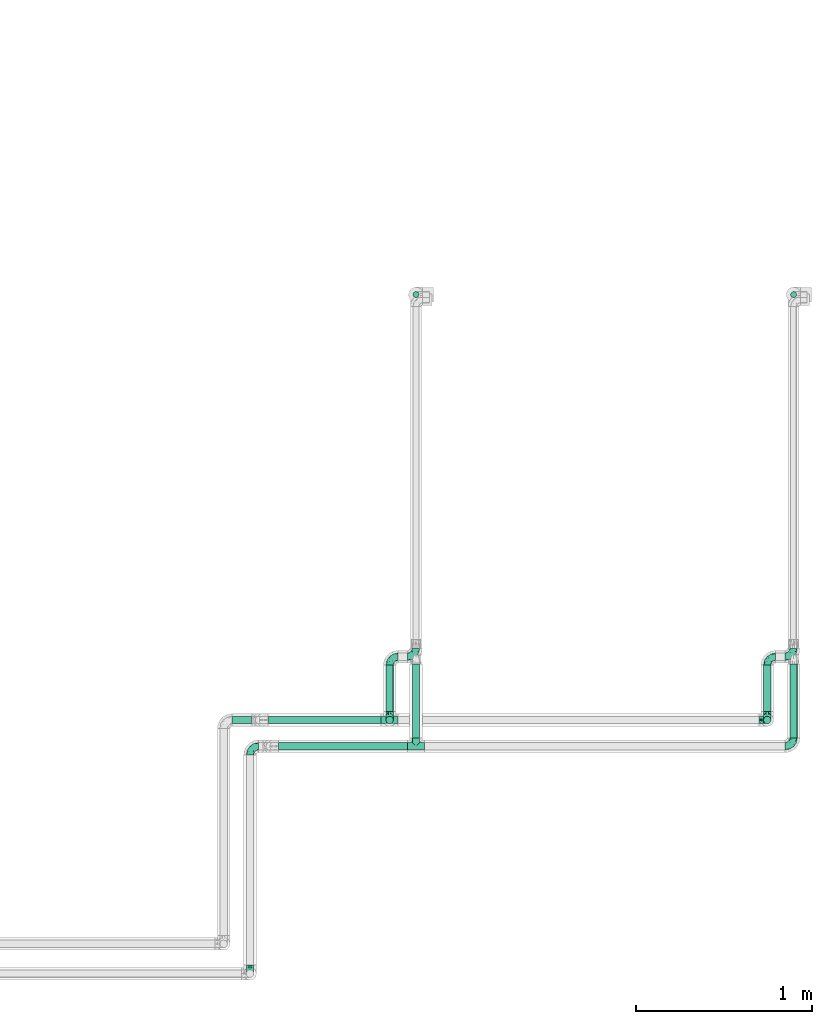
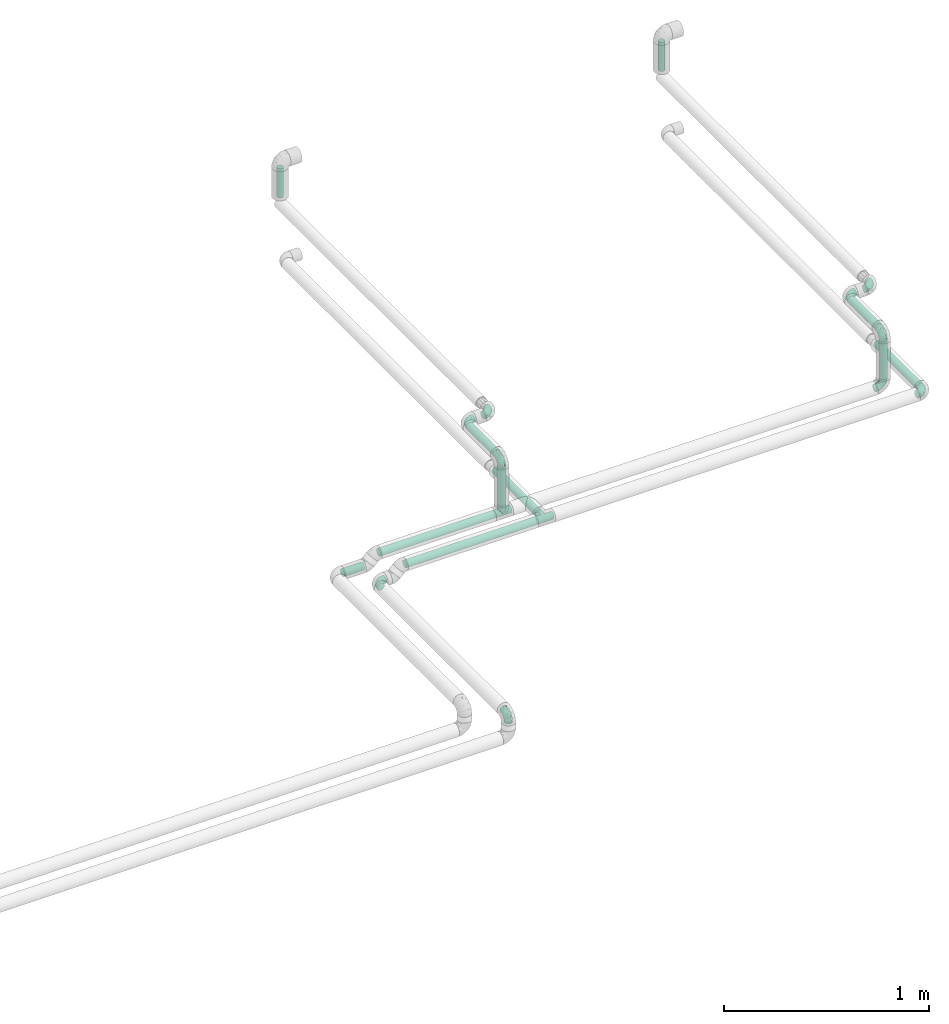
# One storey, part 29 of 39: 12 flow fittings, 11 flow segments.
"""IFC2X3 building model written with IfcOpenShell, lengths in millimetres."""

from ifc_helpers import new_model, entity, si_unit, converted_unit, derived_unit, direction, frame, origin, origin_2d_with_axis, place, context, subcontext, project, spatial, circle, extrude, faceted_brep, source, transform, mapped, material, type_object, type_shapes, element, save


model = new_model("IFC2X3")

# Units and contexts
model_context = context("Model", 3, precision=0.01, world=origin(), true_north=direction((6.12303176911189e-17, 1.0)))
body_context = subcontext(model_context, "Body", "Model", "MODEL_VIEW")
ifc_project = project(units=[si_unit("LENGTHUNIT", "METRE", prefix="MILLI"), si_unit("AREAUNIT", "SQUARE_METRE"), si_unit("VOLUMEUNIT", "CUBIC_METRE"), converted_unit("PLANEANGLEUNIT", "DEGREE", entity("IfcRatioMeasure", 0.0174532925199433), si_unit("PLANEANGLEUNIT", "RADIAN"), dimensions=[0, 0, 0, 0, 0, 0, 0]), si_unit("MASSUNIT", "GRAM", prefix="KILO"), derived_unit("MASSDENSITYUNIT", [(si_unit("MASSUNIT", "GRAM", prefix="KILO"), 1), (si_unit("LENGTHUNIT", "METRE"), -3)]), derived_unit("MOMENTOFINERTIAUNIT", [(si_unit("LENGTHUNIT", "METRE"), 4)]), si_unit("TIMEUNIT", "SECOND"), si_unit("FREQUENCYUNIT", "HERTZ"), si_unit("THERMODYNAMICTEMPERATUREUNIT", "DEGREE_CELSIUS"), derived_unit("THERMALTRANSMITTANCEUNIT", [(si_unit("MASSUNIT", "GRAM", prefix="KILO"), 1), (si_unit("THERMODYNAMICTEMPERATUREUNIT", "KELVIN"), -1), (si_unit("TIMEUNIT", "SECOND"), -3)]), derived_unit("VOLUMETRICFLOWRATEUNIT", [(si_unit("LENGTHUNIT", "METRE"), 3), (si_unit("TIMEUNIT", "SECOND"), -1)]), derived_unit("MASSFLOWRATEUNIT", [(si_unit("MASSUNIT", "GRAM", prefix="KILO"), 1), (si_unit("TIMEUNIT", "SECOND"), -1)]), derived_unit("ROTATIONALFREQUENCYUNIT", [(si_unit("TIMEUNIT", "SECOND"), -1)]), si_unit("ELECTRICCURRENTUNIT", "AMPERE"), si_unit("ELECTRICVOLTAGEUNIT", "VOLT"), si_unit("POWERUNIT", "WATT"), si_unit("FORCEUNIT", "NEWTON", prefix="KILO"), si_unit("ILLUMINANCEUNIT", "LUX"), si_unit("LUMINOUSFLUXUNIT", "LUMEN"), si_unit("LUMINOUSINTENSITYUNIT", "CANDELA"), derived_unit("USERDEFINED", [(si_unit("MASSUNIT", "GRAM", prefix="KILO"), -1), (si_unit("LENGTHUNIT", "METRE"), -2), (si_unit("TIMEUNIT", "SECOND"), 3), (si_unit("LUMINOUSFLUXUNIT", "LUMEN"), 1)]), derived_unit("LINEARVELOCITYUNIT", [(si_unit("LENGTHUNIT", "METRE"), 1), (si_unit("TIMEUNIT", "SECOND"), -1)]), si_unit("PRESSUREUNIT", "PASCAL"), derived_unit("USERDEFINED", [(si_unit("LENGTHUNIT", "METRE"), -2), (si_unit("MASSUNIT", "GRAM", prefix="KILO"), 1), (si_unit("TIMEUNIT", "SECOND"), -2)]), derived_unit("LINEARFORCEUNIT", [(si_unit("MASSUNIT", "GRAM", prefix="KILO"), 1), (si_unit("LENGTHUNIT", "METRE"), 1), (si_unit("TIMEUNIT", "SECOND"), -2), (si_unit("LENGTHUNIT", "METRE"), -1)]), derived_unit("PLANARFORCEUNIT", [(si_unit("MASSUNIT", "GRAM", prefix="KILO"), 1), (si_unit("LENGTHUNIT", "METRE"), 1), (si_unit("TIMEUNIT", "SECOND"), -2), (si_unit("LENGTHUNIT", "METRE"), -2)])], contexts=[model_context])

# Site, building, storey
site_placement = place(None, origin())
site = spatial("IfcSite", under=ifc_project, at=site_placement, CompositionType="ELEMENT")
building_placement = place(site_placement, origin())
building = spatial("IfcBuilding", under=site, at=building_placement, CompositionType="ELEMENT")
storey_placement = place(building_placement, frame((0.0, 0.0, 24000.0)))
storey = spatial("IfcBuildingStorey", under=building, at=storey_placement, Name="07", CompositionType="ELEMENT", Elevation=24000.0)

# Flow segments
pipe_segment_type = type_object("IfcPipeSegmentType", PredefinedType="NOTDEFINED")
flow_segment_1_placement = place(storey_placement, frame((68771.89, 2852.61, 3057.25)))
element("IfcFlowSegment", 1, at=flow_segment_1_placement, inside=storey, type_object=pipe_segment_type, context=body_context, shape_type="SweptSolid", body=[
    extrude(circle(Radius=21.15, at=origin_2d_with_axis()), frame((0.0, 22.75, 22.75), z_axis=(1.0, 0.0, 0.0), x_axis=(0.0, 1.0, 0.0)), (0.0, 0.0, 1.0), 645.120882763224),
])
flow_segment_2_placement = place(storey_placement, frame((68832.77, 2702.61, 3057.21)))
element("IfcFlowSegment", 2, at=flow_segment_2_placement, inside=storey, type_object=pipe_segment_type, context=body_context, shape_type="SweptSolid", body=[
    extrude(circle(Radius=21.15, at=origin_2d_with_axis()), frame((0.0, 22.75, 22.75), z_axis=(1.0, 0.0, 1.50942445489092e-05), x_axis=(0.0, 1.0, 0.0)), (0.0, 0.0, 1.0), 734.245453428102),
])
flow_segment_3_placement = place(storey_placement, frame((68568.08, 2852.61, 3007.23)))
element("IfcFlowSegment", 3, at=flow_segment_3_placement, inside=storey, type_object=pipe_segment_type, context=body_context, shape_type="SweptSolid", body=[
    extrude(circle(Radius=21.15, at=origin_2d_with_axis()), frame((114.01, 22.75, 22.75), z_axis=(-0.999999991447934, 2.11779484169515e-05, 0.000129056682198737), x_axis=(2.11779485933175e-05, 1.0, 0.0)), (0.0, 0.0, 1.0), 114.004835097403),
])
flow_segment_4_placement = place(storey_placement, frame((71746.67, 5279.01, 3438.0)))
element("IfcFlowSegment", 4, at=flow_segment_4_placement, inside=storey, type_object=pipe_segment_type, context=body_context, shape_type="SweptSolid", body=[
    extrude(circle(Radius=16.75, at=origin_2d_with_axis()), frame((18.35, 18.35, 0.0)), (0.0, 0.0, 1.0), 174.000000000017),
])
flow_segment_5_placement = place(storey_placement, frame((71592.27, 2852.61, 3128.0)))
element("IfcFlowSegment", 5, at=flow_segment_5_placement, inside=storey, type_object=pipe_segment_type, context=body_context, shape_type="SweptSolid", body=[
    extrude(circle(Radius=21.15, at=origin_2d_with_axis()), frame((22.75, 22.75, 0.0), z_axis=(0.0, 0.0, 1.0), x_axis=(-1.0, 0.0, 0.0)), (0.0, 0.0, 1.0), 224.000000000018),
])
flow_segment_6_placement = place(storey_placement, frame((71592.27, 2923.35, 3377.25)))
element("IfcFlowSegment", 6, at=flow_segment_6_placement, inside=storey, type_object=pipe_segment_type, context=body_context, shape_type="SweptSolid", body=[
    extrude(circle(Radius=21.15, at=origin_2d_with_axis()), frame((22.75, 0.0, 22.75), z_axis=(0.0, 1.0, 0.0), x_axis=(1.0, 0.0, 0.0)), (0.0, 0.0, 1.0), 264.00000000001),
])
flow_segment_7_placement = place(storey_placement, frame((71742.27, 2773.35, 3057.25)))
element("IfcFlowSegment", 7, at=flow_segment_7_placement, inside=storey, type_object=pipe_segment_type, context=body_context, shape_type="SweptSolid", body=[
    extrude(circle(Radius=21.15, at=origin_2d_with_axis()), frame((22.75, 0.0, 22.75), z_axis=(0.0, 1.0, 0.0), x_axis=(-1.0, 0.0, 0.0)), (0.0, 0.0, 1.0), 422.00000000038),
])
flow_segment_8_placement = place(storey_placement, frame((69596.67, 5279.01, 3438.0)))
element("IfcFlowSegment", 8, at=flow_segment_8_placement, inside=storey, type_object=pipe_segment_type, context=body_context, shape_type="SweptSolid", body=[
    extrude(circle(Radius=16.75, at=origin_2d_with_axis()), frame((18.35, 18.35, 0.0)), (0.0, 0.0, 1.0), 174.000000000017),
])
flow_segment_9_placement = place(storey_placement, frame((69442.27, 2923.35, 3377.25)))
element("IfcFlowSegment", 9, at=flow_segment_9_placement, inside=storey, type_object=pipe_segment_type, context=body_context, shape_type="SweptSolid", body=[
    extrude(circle(Radius=21.15, at=origin_2d_with_axis()), frame((22.75, 0.0, 22.75), z_axis=(0.0, 1.0, 0.0), x_axis=(-1.0, 0.0, 0.0)), (0.0, 0.0, 1.0), 264.000000000017),
])
flow_segment_10_placement = place(storey_placement, frame((69592.27, 2773.35, 3057.22)))
element("IfcFlowSegment", 10, at=flow_segment_10_placement, inside=storey, type_object=pipe_segment_type, context=body_context, shape_type="SweptSolid", body=[
    extrude(circle(Radius=21.15, at=origin_2d_with_axis()), frame((22.75, 0.0, 22.75), z_axis=(0.0, 0.999999996652785, 8.18194919635431e-05), x_axis=(-1.0, 0.0, 0.0)), (0.0, 0.0, 1.0), 422.00000141289),
])
flow_segment_11_placement = place(storey_placement, frame((69442.27, 2852.61, 3128.0)))
element("IfcFlowSegment", 11, at=flow_segment_11_placement, inside=storey, type_object=pipe_segment_type, context=body_context, shape_type="SweptSolid", body=[
    extrude(circle(Radius=21.15, at=origin_2d_with_axis()), frame((22.75, 22.75, 0.0), z_axis=(0.0, 0.0, 1.0), x_axis=(-1.0, 0.0, 0.0)), (0.0, 0.0, 1.0), 224.000000000031),
])

# Flow fittings
ifc_material = material()
pipe_fitting_type_1 = type_object("IfcPipeFittingType", Name="ADSK_1", PredefinedType="NOTDEFINED", material=ifc_material)
shared_shape_1 = source(origin(), body_context, "Body", "Brep", [
    faceted_brep([(-48.0, 10.6, -18.36), (-48.0, 5.49, -20.48), (-48.0, 0.0, -21.2), (-48.0, -5.49, -20.48), (-48.0, -10.6, -18.36), (-48.0, -14.99, -14.99), (-48.0, -18.36, -10.6), (-48.0, -20.48, -5.49), (-48.0, -21.2, 0.0), (-48.0, -20.48, 5.49), (-48.0, -18.36, 10.6), (-48.0, -14.99, 14.99), (-48.0, -10.6, 18.36), (-48.0, -5.49, 20.48), (-48.0, 0.0, 21.2), (-48.0, 5.49, 20.48), (-48.0, 10.6, 18.36), (-48.0, 14.99, 14.99), (-48.0, 18.36, 10.6), (-48.0, 20.48, 5.49), (-48.0, 21.2, 0.0), (-48.0, 20.48, -5.49), (-48.0, 18.36, -10.6), (-48.0, 14.99, -14.99), (0.0, 48.0, -21.2), (-5.49, 48.0, -20.48), (-10.6, 48.0, -18.36), (-14.99, 48.0, -14.99), (-18.36, 48.0, -10.6), (-20.48, 48.0, -5.49), (-21.2, 48.0, 0.0), (-20.48, 48.0, 5.49), (-18.36, 48.0, 10.6), (-14.99, 48.0, 14.99), (-10.6, 48.0, 18.36), (-5.49, 48.0, 20.48), (0.0, 48.0, 21.2), (5.49, 48.0, 20.48), (10.6, 48.0, 18.36), (14.99, 48.0, 14.99), (18.36, 48.0, 10.6), (20.48, 48.0, 5.49), (21.2, 48.0, 0.0), (20.48, 48.0, -5.49), (18.36, 48.0, -10.6), (14.99, 48.0, -14.99), (10.6, 48.0, -18.36), (5.49, 48.0, -20.48), (-35.25, -16.22, 12.01), (-34.76, -18.57, 0.0), (-20.87, -12.37, 10.9), (-31.49, -11.78, 15.9), (-37.0, -2.58, 20.86), (-33.89, 3.62, 21.15), (-31.81, -18.14, 6.76), (-5.78, 5.78, 17.67), (-19.42, -4.1, 17.86), (-9.6, -3.39, 13.73), (-35.44, -7.73, 19.13), (11.78, 31.49, 15.9), (-5.93, -5.46, 6.95), (-18.45, -13.78, 5.46), (-10.29, -8.43, 0.0), (-24.6, 0.55, 20.62), (-37.28, 17.94, 13.81), (-33.38, 22.85, 9.59), (-41.46, 20.06, 8.75), (-29.51, 20.45, 15.16), (-15.04, 10.79, 21.13), (-7.08, 16.98, 20.93), (-8.39, 23.51, 21.15), (-40.86, 13.03, 17.26), (-8.05, 41.26, 19.83), (-3.21, 35.97, 21.14), (8.53, 19.66, 14.74), (4.1, 19.42, 17.86), (-37.72, 22.66, 4.78), (-37.07, 8.58, 19.98), (-13.0, 5.43, 19.97), (-3.78, 13.93, 19.7), (3.02, 8.69, 13.43), (-2.27, -0.05, 10.65), (6.22, 6.99, 7.09), (-22.25, 34.6, 9.45), (18.14, 31.81, 6.76), (16.22, 35.25, 12.01), (12.37, 20.87, 10.9), (7.73, 35.44, 19.13), (-21.52, -15.93, 0.0), (2.58, 37.0, 20.86), (18.57, 34.76, 0.0), (13.78, 18.45, 5.46), (15.93, 21.52, 0.0), (-20.03, -8.54, 14.9), (-28.6, 28.6, 5.16), (-24.79, 34.6, 0.0), (-34.6, 24.79, 0.0), (-22.81, 37.41, 4.68), (-23.36, 26.33, 14.79), (-13.68, 37.05, 17.49), (-17.72, 38.12, 13.73), (-26.25, 27.3, 11.24), (-9.71, 32.34, 20.14), (-17.26, 25.6, 18.71), (-26.33, 9.99, 20.77), (-24.06, 6.05, 21.2), (-25.02, 15.46, 19.56), (-24.3, 20.72, 17.57), (-31.95, 15.23, 17.8), (-13.53, 24.7, 20.21), (-17.6, 17.6, 20.6), (-0.55, 24.6, 20.62), (-11.41, -7.48, 10.43), (0.93, -0.93, 0.0), (8.43, 10.29, 0.0), (-11.41, -7.48, -10.43), (-20.1, -8.84, -14.66), (-9.6, -3.39, -13.73), (7.73, 35.44, -19.13), (4.1, 19.42, -17.86), (-0.55, 24.6, -20.62), (-38.12, 17.72, -13.73), (-37.05, 13.68, -17.49), (-32.34, 9.71, -20.14), (-41.26, 8.05, -19.83), (-37.41, 22.81, -4.68), (-23.51, 8.39, -21.15), (-35.97, 3.21, -21.14), (-28.6, 28.6, -5.16), (-31.81, -18.14, -6.76), (-18.45, -13.78, -5.46), (-25.6, 17.26, -18.71), (-19.42, -4.1, -17.86), (-17.94, 37.28, -13.81), (-22.85, 33.38, -9.59), (-20.06, 41.46, -8.75), (-31.49, -11.78, -15.9), (-35.25, -16.22, -12.01), (8.53, 19.66, -14.74), (11.78, 31.49, -15.9), (-9.99, 26.33, -20.77), (-6.05, 24.06, -21.2), (-10.79, 15.04, -21.13), (-37.0, -2.58, -20.86), (-16.98, 7.08, -20.93), (-5.43, 13.0, -19.97), (-13.93, 3.78, -19.7), (-20.87, -12.37, -10.9), (-26.33, 23.36, -14.79), (-22.66, 37.72, -4.78), (13.78, 18.45, -5.46), (18.14, 31.81, -6.76), (-15.46, 25.02, -19.56), (-20.72, 24.3, -17.57), (16.22, 35.25, -12.01), (-13.03, 40.86, -17.26), (-8.58, 37.07, -19.98), (2.58, 37.0, -20.86), (-3.62, 33.89, -21.15), (-34.6, 22.25, -9.45), (6.22, 6.99, -7.09), (-20.45, 29.51, -15.16), (-35.44, -7.73, -19.13), (12.37, 20.87, -10.9), (-27.3, 26.25, -11.24), (-15.23, 31.95, -17.8), (-24.7, 13.53, -20.21), (-24.6, 0.55, -20.62), (-5.78, 5.78, -17.67), (-17.6, 17.6, -20.6), (3.02, 8.69, -13.43), (-5.93, -5.46, -6.95), (-2.27, -0.05, -10.65)], [[[0, 1, 2, 3, 4, 5, 6, 7, 8, 9, 10, 11, 12, 13, 14, 15, 16, 17, 18, 19, 20, 21, 22, 23]], [[24, 25, 26, 27, 28, 29, 30, 31, 32, 33, 34, 35, 36, 37, 38, 39, 40, 41, 42, 43, 44, 45, 46, 47]], [[10, 48, 11]], [[9, 8, 49]], [[48, 50, 51]], [[14, 52, 53]], [[10, 54, 48]], [[9, 54, 10]], [[55, 56, 57]], [[51, 12, 11]], [[51, 58, 12]], [[59, 39, 38]], [[60, 61, 62]], [[58, 56, 63]], [[64, 65, 66]], [[67, 65, 64]], [[68, 69, 70]], [[16, 71, 17]], [[13, 52, 14]], [[35, 72, 73]], [[14, 53, 15]], [[17, 64, 18]], [[74, 59, 75]], [[20, 19, 76]], [[66, 19, 18]], [[77, 15, 53]], [[15, 77, 16]], [[69, 78, 79]], [[80, 81, 82]], [[32, 31, 83]], [[84, 85, 86]], [[59, 87, 75]], [[61, 54, 88]], [[36, 89, 37]], [[84, 41, 40]], [[36, 35, 73]], [[90, 41, 84]], [[40, 39, 85]], [[12, 58, 13]], [[85, 84, 40]], [[91, 84, 86]], [[84, 92, 90]], [[87, 38, 37]], [[93, 56, 51]], [[65, 94, 76]], [[94, 95, 96]], [[84, 91, 92]], [[95, 97, 30]], [[98, 99, 100]], [[76, 94, 96]], [[101, 98, 83]], [[100, 99, 33]], [[102, 70, 73]], [[103, 102, 99]], [[94, 97, 95]], [[72, 99, 102]], [[72, 35, 34]], [[34, 33, 99]], [[9, 49, 54]], [[87, 59, 38]], [[104, 105, 68]], [[106, 103, 107]], [[106, 77, 104]], [[71, 64, 17]], [[108, 107, 67]], [[33, 32, 100]], [[109, 103, 110]], [[102, 109, 70]], [[89, 73, 111]], [[50, 48, 54]], [[51, 11, 48]], [[56, 58, 51]], [[88, 54, 49]], [[52, 58, 63]], [[50, 112, 93]], [[56, 55, 78]], [[39, 59, 85]], [[86, 85, 59]], [[89, 87, 37]], [[42, 41, 90]], [[111, 79, 75]], [[111, 75, 87]], [[75, 55, 80]], [[104, 77, 53]], [[71, 77, 108]], [[32, 83, 100]], [[98, 100, 83]], [[99, 98, 103]], [[106, 107, 108]], [[68, 70, 110]], [[111, 73, 70]], [[68, 110, 104]], [[68, 63, 78]], [[57, 93, 112]], [[80, 55, 57]], [[61, 50, 54]], [[80, 82, 86]], [[81, 57, 112]], [[74, 86, 59]], [[60, 113, 82]], [[82, 114, 91]], [[101, 94, 65]], [[97, 94, 83]], [[73, 89, 36]], [[87, 89, 111]], [[58, 52, 13]], [[53, 52, 63]], [[104, 53, 105]], [[106, 104, 110]], [[20, 76, 96]], [[76, 19, 66]], [[103, 106, 110]], [[77, 106, 108]], [[103, 98, 107]], [[67, 107, 98]], [[67, 98, 101]], [[108, 67, 64]], [[53, 63, 105]], [[63, 68, 105]], [[83, 31, 97]], [[30, 97, 31]], [[62, 113, 60]], [[112, 61, 60]], [[61, 88, 62]], [[86, 82, 91]], [[56, 78, 63]], [[114, 82, 113]], [[114, 92, 91]], [[79, 78, 55]], [[75, 79, 55]], [[69, 79, 111]], [[70, 69, 111]], [[78, 69, 68]], [[77, 71, 16]], [[64, 71, 108]], [[64, 66, 18]], [[76, 66, 65]], [[99, 72, 34]], [[73, 72, 102]], [[94, 101, 83]], [[67, 101, 65]], [[75, 80, 74]], [[80, 86, 74]], [[70, 109, 110]], [[102, 103, 109]], [[50, 93, 51]], [[57, 56, 93]], [[61, 112, 50]], [[81, 112, 60]], [[82, 81, 60]], [[80, 57, 81]], [[115, 116, 117]], [[118, 119, 120]], [[121, 122, 23]], [[123, 124, 122]], [[96, 125, 20]], [[123, 126, 127]], [[128, 96, 95]], [[129, 130, 88]], [[123, 122, 131]], [[116, 132, 117]], [[133, 134, 135]], [[0, 124, 1]], [[5, 136, 137]], [[138, 119, 139]], [[129, 88, 49]], [[140, 141, 142]], [[6, 5, 137]], [[46, 118, 47]], [[143, 3, 2]], [[144, 145, 146]], [[6, 129, 7]], [[129, 137, 147]], [[127, 2, 1]], [[148, 122, 121]], [[128, 125, 96]], [[134, 128, 149]], [[95, 149, 128]], [[150, 151, 92]], [[30, 29, 149]], [[152, 131, 153]], [[27, 133, 28]], [[154, 45, 44]], [[136, 5, 4]], [[27, 26, 155]], [[156, 26, 25]], [[24, 157, 158]], [[24, 47, 157]], [[22, 21, 159]], [[160, 150, 114]], [[134, 133, 161]], [[142, 144, 126]], [[46, 139, 118]], [[162, 136, 4]], [[156, 25, 158]], [[1, 124, 127]], [[115, 147, 116]], [[45, 154, 139]], [[139, 46, 45]], [[154, 163, 139]], [[162, 4, 3]], [[42, 90, 43]], [[130, 129, 147]], [[49, 7, 129]], [[43, 151, 44]], [[0, 23, 122]], [[24, 158, 25]], [[136, 162, 132]], [[135, 29, 28]], [[43, 90, 151]], [[164, 148, 159]], [[152, 156, 140]], [[155, 133, 27]], [[165, 153, 161]], [[23, 22, 121]], [[123, 131, 166]], [[123, 166, 126]], [[143, 127, 167]], [[147, 137, 136]], [[8, 7, 49]], [[129, 6, 137]], [[143, 162, 3]], [[167, 146, 132]], [[167, 132, 162]], [[132, 168, 117]], [[44, 151, 154]], [[92, 151, 90]], [[163, 154, 151]], [[119, 118, 139]], [[157, 118, 120]], [[138, 139, 163]], [[119, 168, 145]], [[140, 156, 158]], [[155, 156, 165]], [[22, 159, 121]], [[148, 121, 159]], [[122, 148, 131]], [[152, 153, 165]], [[142, 126, 169]], [[167, 127, 126]], [[142, 169, 140]], [[142, 120, 145]], [[168, 170, 117]], [[160, 171, 172]], [[115, 172, 171]], [[171, 62, 130]], [[119, 170, 168]], [[170, 163, 160]], [[150, 163, 151]], [[113, 171, 160]], [[164, 128, 134]], [[125, 128, 159]], [[127, 143, 2]], [[162, 143, 167]], [[118, 157, 47]], [[158, 157, 120]], [[140, 158, 141]], [[152, 140, 169]], [[30, 149, 95]], [[149, 29, 135]], [[131, 152, 169]], [[156, 152, 165]], [[131, 148, 153]], [[161, 153, 148]], [[161, 148, 164]], [[165, 161, 133]], [[158, 120, 141]], [[120, 142, 141]], [[159, 21, 125]], [[20, 125, 21]], [[115, 130, 147]], [[114, 113, 160]], [[62, 171, 113]], [[62, 88, 130]], [[160, 163, 150]], [[150, 92, 114]], [[119, 145, 120]], [[146, 145, 168]], [[132, 146, 168]], [[144, 146, 167]], [[126, 144, 167]], [[145, 144, 142]], [[156, 155, 26]], [[133, 155, 165]], [[133, 135, 28]], [[149, 135, 134]], [[122, 124, 0]], [[127, 124, 123]], [[128, 164, 159]], [[161, 164, 134]], [[163, 170, 138]], [[170, 119, 138]], [[131, 169, 166]], [[126, 166, 169]], [[147, 136, 116]], [[132, 116, 136]], [[172, 115, 117]], [[130, 115, 171]], [[117, 170, 172]], [[160, 172, 170]]]),
])
type_shapes(pipe_fitting_type_1, [shared_shape_1])
for number, where, z_axis, x_axis, name in (
    (12, (68670.08, 2725.35, 3029.95), (-1.53605278439565e-05, 0.0, 1.0), (-1.0, 0.0, -1.53605278439565e-05), "ADSK_1"),
    (13, (71615.01, 2875.35, 3080.0), (0.0, -1.0, 0.0), (1.0, 0.0, 0.0), "ADSK_1"),
    (14, (71615.01, 2875.35, 3400.0), (-1.0, 0.0, 0.0), (0.0, 0.0, 1.0), "ADSK_1"),
    (15, (71615.01, 3235.35, 3400.0), (0.0, 0.0, 1.0), (-1.0, 0.0, 0.0), "ADSK_1"),
):
    element("IfcFlowFitting", number, at=place(storey_placement, frame(where, z_axis=z_axis, x_axis=x_axis)), inside=storey, type_object=pipe_fitting_type_1, material=ifc_material, Name=name, ObjectType="ADSK_1", context=body_context, shape_type="MappedRepresentation", body=[
        mapped(shared_shape_1, transform((0.0, 0.0, 0.0), scale=1.0)),
    ])
for number, where, name in (
    (16, (71765.01, 3235.35, 3400.0), "ADSK_1"),
    (17, (71765.01, 2725.35, 3080.0), "ADSK_1"),
    (18, (69615.01, 3235.35, 3400.0), "ADSK_1"),
):
    element("IfcFlowFitting", number, at=place(storey_placement, frame(where)), inside=storey, type_object=pipe_fitting_type_1, material=ifc_material, Name=name, ObjectType="ADSK_1", context=body_context, shape_type="MappedRepresentation", body=[
        mapped(shared_shape_1, transform((0.0, 0.0, 0.0), scale=1.0)),
    ])
for number, where, z_axis, x_axis, name in (
    (19, (69465.01, 3235.35, 3400.0), (0.0, 0.0, 1.0), (-1.0, 0.0, 0.0), "ADSK_1"),
    (20, (69465.01, 2875.35, 3400.0), (-1.0, 0.0, 0.0), (0.0, 0.0, 1.0), "ADSK_1"),
    (21, (68670.08, 1431.17, 3029.95), (1.0, 0.0, 0.0), (0.0, -1.0, 0.0), "ADSK_1"),
):
    element("IfcFlowFitting", number, at=place(storey_placement, frame(where, z_axis=z_axis, x_axis=x_axis)), inside=storey, type_object=pipe_fitting_type_1, material=ifc_material, Name=name, ObjectType="ADSK_1", context=body_context, shape_type="MappedRepresentation", body=[
        mapped(shared_shape_1, transform((0.0, 0.0, 0.0), scale=1.0)),
    ])
pipe_fitting_type_2 = type_object("IfcPipeFittingType", Name="ADSK_1", PredefinedType="NOTDEFINED", material=ifc_material)
shared_shape_2 = source(origin(), body_context, "Body", "Brep", [
    faceted_brep([(-48.0, 10.6, -18.36), (-48.0, 5.49, -20.48), (-48.0, 0.0, -21.2), (-48.0, -5.49, -20.48), (-48.0, -10.6, -18.36), (-48.0, -14.99, -14.99), (-48.0, -18.36, -10.6), (-48.0, -20.48, -5.49), (-48.0, -21.2, 0.0), (-48.0, -20.48, 5.49), (-48.0, -18.36, 10.6), (-48.0, -14.99, 14.99), (-48.0, -10.6, 18.36), (-48.0, -5.49, 20.48), (-48.0, 0.0, 21.2), (-48.0, 5.49, 20.48), (-48.0, 10.6, 18.36), (-48.0, 14.99, 14.99), (-48.0, 18.36, 10.6), (-48.0, 20.48, 5.49), (-48.0, 21.2, 0.0), (-48.0, 20.48, -5.49), (-48.0, 18.36, -10.6), (-48.0, 14.99, -14.99), (48.0, 0.0, -21.2), (48.0, 5.49, -20.48), (48.0, 10.6, -18.36), (48.0, 14.99, -14.99), (48.0, 18.36, -10.6), (48.0, 20.48, -5.49), (48.0, 21.2, 0.0), (48.0, 20.48, 5.49), (48.0, 18.36, 10.6), (48.0, 14.99, 14.99), (48.0, 10.6, 18.36), (48.0, 5.49, 20.48), (48.0, 0.0, 21.2), (48.0, -5.49, 20.48), (48.0, -10.6, 18.36), (48.0, -14.99, 14.99), (48.0, -18.36, 10.6), (48.0, -20.48, 5.49), (48.0, -21.2, 0.0), (48.0, -20.48, -5.49), (48.0, -18.36, -10.6), (48.0, -14.99, -14.99), (48.0, -10.6, -18.36), (48.0, -5.49, -20.48), (20.43, -20.43, 5.66), (21.2, -21.2, 0.0), (-21.2, -21.2, 0.0), (18.35, -18.35, 10.62), (11.88, -11.88, 17.56), (15.38, -15.38, 14.59), (-20.43, -20.43, 5.66), (-18.35, -18.35, 10.62), (-15.38, -15.38, 14.59), (-11.88, -11.88, 17.56), (-8.06, -8.06, 19.61), (8.06, -8.06, 19.61), (4.07, -4.07, 20.81), (0.0, 0.0, 21.2), (-4.07, -4.07, 20.81), (4.07, -4.07, -20.81), (0.0, 0.0, -21.2), (-4.07, -4.07, -20.81), (-8.06, -8.06, -19.61), (8.06, -8.06, -19.61), (11.88, -11.88, -17.56), (15.38, -15.38, -14.59), (18.35, -18.35, -10.62), (20.43, -20.43, -5.66), (-11.88, -11.88, -17.56), (-15.38, -15.38, -14.59), (-20.43, -20.43, -5.66), (-18.35, -18.35, -10.62), (0.0, -48.0, -21.2), (5.49, -48.0, -20.48), (10.6, -48.0, -18.36), (14.99, -48.0, -14.99), (18.36, -48.0, -10.6), (20.48, -48.0, -5.49), (21.2, -48.0, 0.0), (20.48, -48.0, 5.49), (18.36, -48.0, 10.6), (14.99, -48.0, 14.99), (10.6, -48.0, 18.36), (5.49, -48.0, 20.48), (0.0, -48.0, 21.2), (-5.49, -48.0, 20.48), (-10.6, -48.0, 18.36), (-14.99, -48.0, 14.99), (-18.36, -48.0, 10.6), (-20.48, -48.0, 5.49), (-21.2, -48.0, 0.0), (-20.48, -48.0, -5.49), (-18.36, -48.0, -10.6), (-14.99, -48.0, -14.99), (-10.6, -48.0, -18.36), (-5.49, -48.0, -20.48)], [[[0, 1, 2, 3, 4, 5, 6, 7, 8, 9, 10, 11, 12, 13, 14, 15, 16, 17, 18, 19, 20, 21, 22, 23]], [[24, 25, 26, 27, 28, 29, 30, 31, 32, 33, 34, 35, 36, 37, 38, 39, 40, 41, 42, 43, 44, 45, 46, 47]], [[41, 40, 48]], [[42, 41, 49]], [[50, 9, 8]], [[49, 41, 48]], [[40, 51, 48]], [[39, 38, 52]], [[51, 40, 53]], [[52, 53, 39]], [[53, 40, 39]], [[50, 54, 9]], [[9, 54, 10]], [[54, 55, 10]], [[56, 57, 11]], [[11, 10, 56]], [[11, 57, 12]], [[56, 10, 55]], [[12, 57, 58]], [[52, 38, 59]], [[60, 36, 61]], [[62, 61, 14]], [[59, 37, 60]], [[37, 59, 38]], [[60, 37, 36]], [[61, 36, 35, 15, 14]], [[32, 31, 19, 18]], [[17, 16, 34, 33]], [[18, 17, 33, 32]], [[35, 34, 16, 15]], [[20, 19, 31, 30]], [[62, 13, 58]], [[13, 62, 14]], [[58, 13, 12]], [[27, 23, 22, 28]], [[22, 21, 29, 28]], [[0, 23, 27, 26]], [[20, 30, 29, 21]], [[24, 47, 63]], [[24, 64, 2, 1, 25]], [[64, 24, 63]], [[2, 64, 65]], [[26, 25, 1, 0]], [[65, 66, 3]], [[2, 65, 3]], [[66, 4, 3]], [[63, 47, 67]], [[46, 45, 68]], [[69, 68, 45]], [[44, 70, 69]], [[69, 45, 44]], [[46, 68, 67]], [[43, 42, 49]], [[7, 50, 8]], [[43, 71, 44]], [[71, 43, 49]], [[44, 71, 70]], [[72, 4, 66]], [[72, 5, 4]], [[5, 72, 73]], [[5, 73, 6]], [[74, 50, 7]], [[75, 74, 6]], [[74, 7, 6]], [[75, 6, 73]], [[46, 67, 47]], [[76, 77, 78, 79, 80, 81, 82, 83, 84, 85, 86, 87, 88, 89, 90, 91, 92, 93, 94, 95, 96, 97, 98, 99]], [[50, 94, 93]], [[54, 50, 93]], [[91, 90, 57]], [[56, 92, 91]], [[54, 93, 92]], [[58, 90, 89]], [[55, 54, 92]], [[56, 55, 92]], [[58, 57, 90]], [[88, 61, 62]], [[58, 89, 62]], [[56, 91, 57]], [[62, 89, 88]], [[60, 88, 87]], [[86, 59, 87]], [[84, 83, 48]], [[53, 85, 84]], [[52, 86, 85]], [[49, 83, 82]], [[59, 60, 87]], [[52, 59, 86]], [[49, 48, 83]], [[51, 53, 84]], [[48, 51, 84]], [[52, 85, 53]], [[88, 60, 61]], [[82, 81, 49]], [[71, 49, 81]], [[69, 80, 79]], [[79, 78, 68]], [[71, 81, 80]], [[67, 78, 77]], [[70, 71, 80]], [[69, 70, 80]], [[67, 68, 78]], [[76, 64, 63]], [[67, 77, 63]], [[69, 79, 68]], [[63, 77, 76]], [[65, 76, 99]], [[98, 66, 99]], [[96, 95, 74]], [[73, 97, 96]], [[72, 98, 97]], [[50, 95, 94]], [[66, 65, 99]], [[72, 66, 98]], [[50, 74, 95]], [[75, 73, 96]], [[74, 75, 96]], [[72, 97, 73]], [[76, 65, 64]]]),
])
type_shapes(pipe_fitting_type_2, [shared_shape_2])
for number, where, z_axis, x_axis, name in (
    (22, (69465.01, 2875.35, 3080.0), (0.0, 1.0, 0.0), (1.0, 0.0, 0.0), "ADSK_1"),
    (23, (69615.01, 2725.35, 3079.97), (1.50942445417509e-05, -3.90443941270139e-06, -1.0), (1.0, 0.0, 1.5094244541866e-05), "ADSK_1"),
):
    element("IfcFlowFitting", number, at=place(storey_placement, frame(where, z_axis=z_axis, x_axis=x_axis)), inside=storey, type_object=pipe_fitting_type_2, material=ifc_material, Name=name, ObjectType="ADSK_1", context=body_context, shape_type="MappedRepresentation", body=[
        mapped(shared_shape_2, transform((0.0, 0.0, 0.0), scale=1.0)),
    ])

save(model, "model.ifc")
